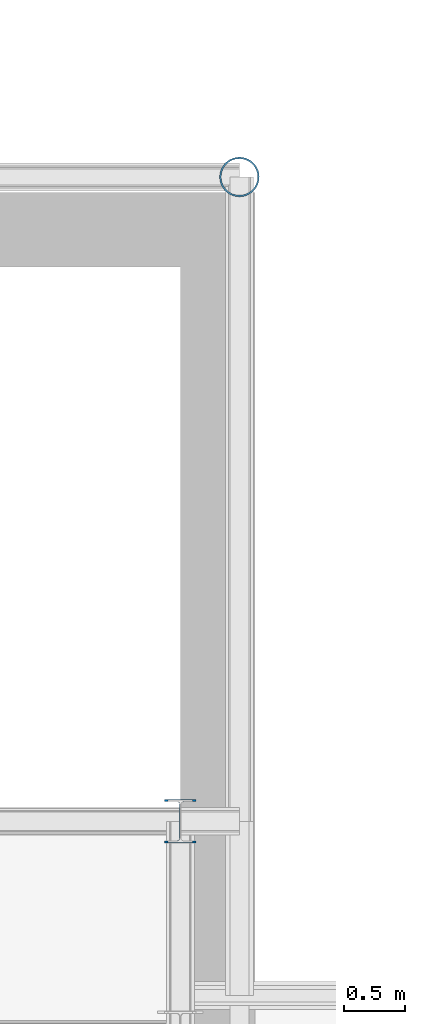
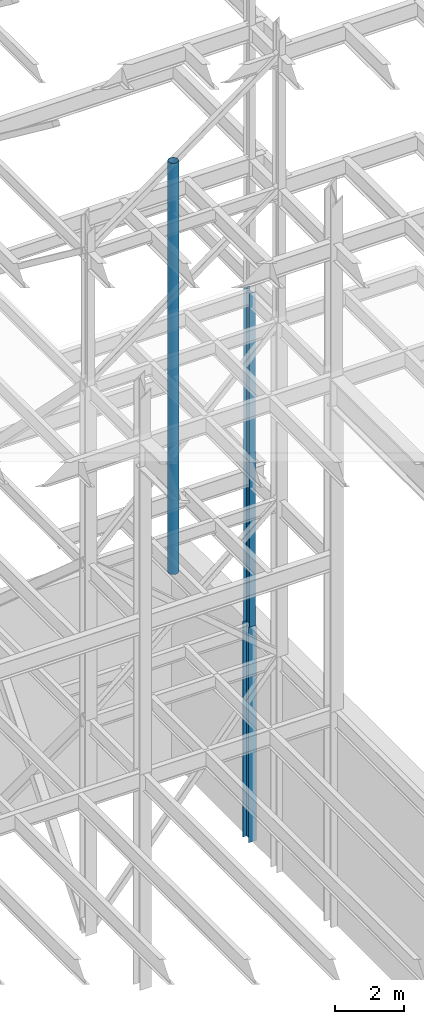
# One storey, part 121 of 150: 6 columns.
"""IFC2X3 building model written with IfcOpenShell, lengths in millimetres."""

from ifc_helpers import new_model, si_unit, frame, origin_with_axes, origin_2d_with_axis, place, context, subcontext, project, spatial, hollow_circle, i_section, extrude, material, type_object, element, save


model = new_model("IFC2X3")

# Units and contexts
model_context = context("Model", 3, precision=1e-05, world=origin_with_axes())
body_context = subcontext(model_context, "Body", "Model", "MODEL_VIEW")
ifc_project = project(units=[si_unit("LENGTHUNIT", "METRE", prefix="MILLI"), si_unit("AREAUNIT", "SQUARE_METRE"), si_unit("VOLUMEUNIT", "CUBIC_METRE"), si_unit("MASSUNIT", "GRAM", prefix="KILO"), si_unit("TIMEUNIT", "SECOND"), si_unit("PLANEANGLEUNIT", "RADIAN"), si_unit("SOLIDANGLEUNIT", "STERADIAN"), si_unit("THERMODYNAMICTEMPERATUREUNIT", "DEGREE_CELSIUS"), si_unit("LUMINOUSINTENSITYUNIT", "LUMEN")], contexts=[model_context])

# Site, building, storey
site_placement = place(None, origin_with_axes())
site = spatial("IfcSite", under=ifc_project, at=site_placement, CompositionType="ELEMENT")
building_placement = place(site_placement, origin_with_axes())
building = spatial("IfcBuilding", under=site, at=building_placement, Name="Undefined", CompositionType="ELEMENT")
storey_placement = place(building_placement, origin_with_axes())
storey = spatial("IfcBuildingStorey", under=building, at=storey_placement, Name="Undefined", CompositionType="ELEMENT", Elevation=0.0)

# Columns
ifc_material_1 = material()
column_type_1 = type_object("IfcColumnType", Name="HSS12.750X0.500", PredefinedType="NOTDEFINED")
for number, where, z_axis, x_axis, name in (
    (1, (89077.8, 32613.6, 22250.4), (0.0, 0.0, 1.0), (1.0, 0.0, 0.0), "COLUMN"),
    (2, (89077.8, 32613.6, 22250.4), (0.0, 0.0, 1.0), (1.0, 0.0, 0.0), "COLUMN"),
    (3, (89077.8, 32613.6, 22250.4), (0.0, 0.0, 1.0), (1.0, 0.0, 0.0), "COLUMN"),
    (4, (89077.8, 32613.6, 22250.4), (0.0, 0.0, 1.0), (1.0, 0.0, 0.0), "COLUMN"),
):
    element("IfcColumn", number, at=place(storey_placement, frame(where, z_axis=z_axis, x_axis=x_axis)), inside=storey, type_object=column_type_1, material=ifc_material_1, Name=name, ObjectType="HSS12.750X0.500", context=body_context, shape_type="SweptSolid", body=[
        extrude(hollow_circle(Radius=161.925, WallThickness=12.7, at=origin_2d_with_axis()), frame((0.0, 0.0, 14554.2), z_axis=(0.0, 0.0, -1.0), x_axis=(-1.0, 0.0, 0.0)), (0.0, 0.0, 1.0), 14554.2),
    ])
ifc_material_2 = material(Name="STEEL/A992")
column_type_2 = type_object("IfcColumnType", Name="W14X53", PredefinedType="NOTDEFINED")
column_1_placement = place(storey_placement, frame((88595.2, 27355.8, 23774.4), z_axis=(0.0, 0.0, 1.0), x_axis=(1.0, 0.0, 0.0)))
element("IfcColumn", 5, at=column_1_placement, inside=storey, type_object=column_type_2, material=ifc_material_2, Name="COLUMN", ObjectType="W14X53", context=body_context, shape_type="SweptSolid", body=[
    extrude(i_section(OverallWidth=203.2, OverallDepth=352.425, WebThickness=9.5249, FlangeThickness=16.764, FilletRadius=21.336, at=origin_2d_with_axis()), frame((0.0, 0.0, 11811.0), z_axis=(0.0, 0.0, -1.0), x_axis=(-1.0, 0.0, 0.0)), (0.0, 0.0, 1.0), 11811.0),
])
column_type_3 = type_object("IfcColumnType", Name="W14X61", PredefinedType="NOTDEFINED")
column_2_placement = place(storey_placement, frame((88595.2, 27355.8, 16154.4), z_axis=(0.0, 0.0, 1.0), x_axis=(1.0, 0.0, 0.0)))
element("IfcColumn", 6, at=column_2_placement, inside=storey, type_object=column_type_3, material=ifc_material_2, Name="COLUMN", ObjectType="W14X61", context=body_context, shape_type="SweptSolid", body=[
    extrude(i_section(OverallWidth=254.0, OverallDepth=352.425, WebThickness=9.5249, FlangeThickness=16.383, FilletRadius=21.717, at=origin_2d_with_axis()), frame((0.0, 0.0, 7620.0), z_axis=(0.0, 0.0, -1.0), x_axis=(-1.0, 0.0, 0.0)), (0.0, 0.0, 1.0), 7620.0),
])

save(model, "model.ifc")
